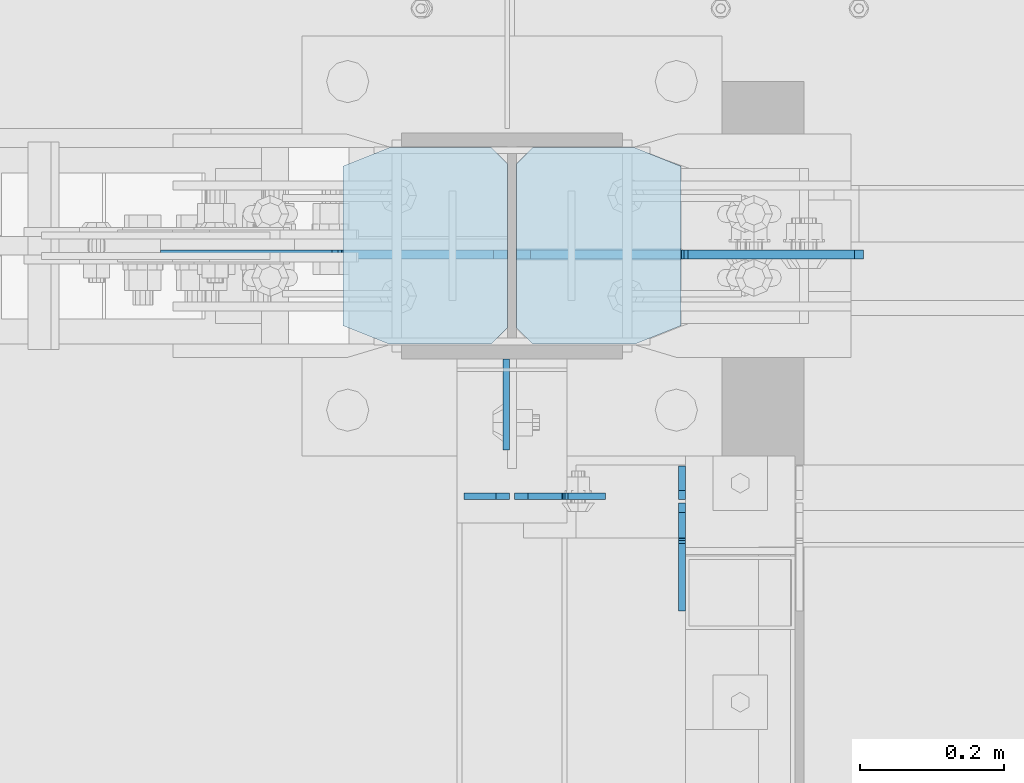
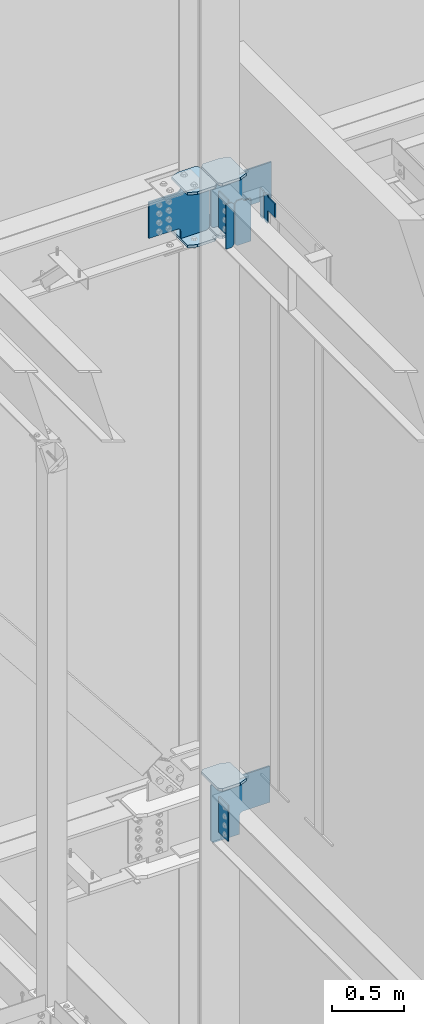
# One storey, part 1106 of 1179: 14 plates, 3 elements without a shape of their own.
"""IFC2X3 building model written with IfcOpenShell, lengths in millimetres."""

from ifc_helpers import new_model, si_unit, frame, origin_with_axes, place, context, subcontext, project, spatial, faceted_brep, material, type_object, element, aggregate, save


model = new_model("IFC2X3")

# Units and contexts
model_context = context("Model", 3, precision=1e-05, world=origin_with_axes())
body_context = subcontext(model_context, "Body", "Model", "MODEL_VIEW")
ifc_project = project(units=[si_unit("LENGTHUNIT", "METRE", prefix="MILLI"), si_unit("AREAUNIT", "SQUARE_METRE"), si_unit("VOLUMEUNIT", "CUBIC_METRE"), si_unit("MASSUNIT", "GRAM", prefix="KILO"), si_unit("TIMEUNIT", "SECOND"), si_unit("PLANEANGLEUNIT", "RADIAN"), si_unit("SOLIDANGLEUNIT", "STERADIAN"), si_unit("THERMODYNAMICTEMPERATUREUNIT", "DEGREE_CELSIUS"), si_unit("LUMINOUSINTENSITYUNIT", "LUMEN")], contexts=[model_context])

# Site, building, storey
site_placement = place(None, origin_with_axes())
site = spatial("IfcSite", under=ifc_project, at=site_placement, CompositionType="ELEMENT")
building_placement = place(site_placement, origin_with_axes())
building = spatial("IfcBuilding", under=site, at=building_placement, Name="Undefined", CompositionType="ELEMENT")
storey_placement = place(building_placement, origin_with_axes())
storey = spatial("IfcBuildingStorey", under=building, at=storey_placement, Name="Undefined", CompositionType="ELEMENT", Elevation=0.0)

# Assembly, plate
assembly_1_placement = place(storey_placement, origin_with_axes())
assembly_1 = element("IfcElementAssembly", 1, at=assembly_1_placement, inside=storey, Name="BEAM", AssemblyPlace="NOTDEFINED", PredefinedType="RIGID_FRAME")
ifc_material_1 = material(Name="STEEL/A36")
plate_type_1 = type_object("IfcPlateType", PredefinedType="NOTDEFINED")
plate_1_placement = place(assembly_1_placement, frame((16462.375, 40850.3442499161, 12728.575), z_axis=(0.0, 0.0, 1.0), x_axis=(1.0, 0.0, 0.0)))
plate_1 = element("IfcPlate", 2, at=plate_1_placement, type_object=plate_type_1, material=ifc_material_1, Name="PLATE", context=body_context, shape_type="Brep", body=[
    faceted_brep([(66.6749998164378, -4.76249999999709, 377.825), (66.6749999434469, -4.76249999999709, 371.474999553748), (66.6749999434469, 4.76249999999709, 371.474999553748), (66.6749998164378, 4.76249999999709, 377.825), (67.641729938794, -4.76249999999709, 366.614920114053), (67.641729938794, 4.76249999999709, 366.614920114053), (70.394743855788, -4.76249999999709, 362.494743732281), (70.394743855788, 4.76249999999709, 362.494743732281), (74.5149202922948, -4.76249999999709, 359.741729897201), (74.5149202922948, 4.76249999999709, 359.741729897201), (79.3749997512095, -4.76249999999709, 358.774999998475), (79.3749997512095, 4.76249999999709, 358.774999998475), (127.000000004868, -4.76249999999709, 358.774999992755), (127.0, 4.76249999999709, 358.774999992755), (0.0, -4.76249999999709, 358.775000762939), (19.0499992370605, -4.76249999999709, 377.825), (19.0499992370605, 4.76249999999709, 377.825), (0.0, 4.76249999999709, 358.775000762939), (0.0, -4.76250000000073, 19.0499992370605), (0.0, 4.76250000000073, 19.0499992370605), (19.0499992370605, -4.76250000000073, 0.0), (19.0499992370605, 4.76250000000073, 0.0), (127.0, -4.76250000000073, 0.0), (127.0, 4.76250000000073, 0.0)], [[[0, 1, 2, 3]], [[4, 5, 2, 1]], [[6, 7, 5, 4]], [[8, 9, 7, 6]], [[10, 11, 9, 8]], [[12, 13, 11, 10]], [[14, 15, 16, 17]], [[18, 14, 17, 19]], [[20, 18, 19, 21]], [[22, 20, 21, 23]], [[8, 6, 4, 1, 0, 15, 14, 18, 20, 22, 12, 10]], [[16, 15, 0, 3]], [[23, 21, 19, 17, 16, 3, 2, 5, 7, 9, 11, 13]], [[22, 23, 13, 12]]]),
])

# Assembly, plates
assembly_2_placement = place(storey_placement, origin_with_axes())
assembly_2 = element("IfcElementAssembly", 3, at=assembly_2_placement, inside=storey, Name="COLUMN", AssemblyPlace="NOTDEFINED", PredefinedType="RIGID_FRAME")
plate_2_placement = place(assembly_2_placement, frame((16451.2625, 41041.6375, 13080.9999983942), z_axis=(0.0, -1.0, 0.0), x_axis=(0.0, 0.0, -1.0)))
plate_2 = element("IfcPlate", 4, at=plate_2_placement, type_object=plate_type_1, material=ifc_material_1, Name="PLATE", context=body_context, shape_type="Brep", body=[
    faceted_brep([(0.0, -4.76249999999709, 0.0), (0.0, -4.76249999999709, 127.0), (0.0, 4.76249999999709, 127.0), (0.0, 4.76249999999709, 0.0), (304.799999999999, -4.76249999999982, 127.0), (304.799999999999, 4.76249999999982, 127.0), (304.799987792969, -4.76250000000073, 0.0), (304.799987792969, 4.76250000000073, 0.0)], [[[0, 1, 2, 3]], [[2, 1, 4, 5]], [[4, 6, 7, 5]], [[6, 0, 3, 7]], [[5, 7, 3, 2]], [[6, 4, 1, 0]]]),
])
plate_3_placement = place(assembly_2_placement, frame((16451.2625, 41041.6375, 7975.59999886453), z_axis=(0.0, -1.0, 0.0), x_axis=(0.0, 0.0, -1.0)))
plate_3 = element("IfcPlate", 5, at=plate_3_placement, type_object=plate_type_1, material=ifc_material_1, Name="PLATE", context=body_context, shape_type="Brep", body=[
    faceted_brep([(0.0, -4.76249999999709, 0.0), (0.0, -4.76249999999709, 127.0), (0.0, 4.76249999999709, 127.0), (0.0, 4.76249999999709, 0.0), (304.799999999999, -4.76249999999982, 127.0), (304.799999999999, 4.76249999999982, 127.0), (304.799987792969, -4.76250000000073, 0.0), (304.799987792969, 4.76250000000073, 0.0)], [[[0, 1, 2, 3]], [[2, 1, 4, 5]], [[4, 6, 7, 5]], [[6, 0, 3, 7]], [[5, 7, 3, 2]], [[6, 4, 1, 0]]]),
])

# Plate
plate_type_2 = type_object("IfcPlateType", PredefinedType="NOTDEFINED")
plate_4_placement = place(assembly_1_placement, frame((16456.025, 40850.3442499161, 12728.575), z_axis=(0.0, 0.0, 1.0), x_axis=(-1.0, 0.0, 0.0)))
plate_4 = element("IfcPlate", 6, at=plate_4_placement, type_object=plate_type_2, material=ifc_material_1, Name="PLATE", context=body_context, shape_type="Brep", body=[
    faceted_brep([(0.0, -4.76250000000073, 19.0499992370605), (0.0, -4.76249999999709, 358.775000762939), (0.0, 4.76249999999709, 358.775000762939), (0.0, 4.76250000000073, 19.0499992370605), (19.0499992370605, -4.76249999999709, 377.825), (19.0499992370605, 4.76249999999709, 377.825), (63.5, -4.76250000000073, 377.825012207031), (63.5, 4.76250000000073, 377.825012207031), (63.5, -4.76250000000073, 0.0), (63.5, 4.76250000000073, 0.0), (19.0499992370605, -4.76250000000073, 0.0), (19.0499992370605, 4.76250000000073, 0.0)], [[[0, 1, 2, 3]], [[1, 4, 5, 2]], [[4, 6, 7, 5]], [[6, 8, 9, 7]], [[8, 10, 11, 9]], [[10, 0, 3, 11]], [[5, 7, 9, 11, 3, 2]], [[10, 8, 6, 4, 1, 0]]]),
])

aggregate(assembly_1, [plate_4, plate_1])

# Assembly, plate
assembly_3_placement = place(storey_placement, origin_with_axes())
assembly_3 = element("IfcElementAssembly", 7, at=assembly_3_placement, inside=storey, Name="BEAM", AssemblyPlace="NOTDEFINED", PredefinedType="RIGID_FRAME")
plate_type_3 = type_object("IfcPlateType", PredefinedType="NOTDEFINED")
plate_5_placement = place(assembly_3_placement, frame((16695.7374982185, 40845.58125, 12874.625), z_axis=(0.0, 0.0, 1.0), x_axis=(0.0, 1.0, 0.0)))
plate_5 = element("IfcPlate", 8, at=plate_5_placement, type_object=plate_type_3, material=ifc_material_1, Name="PLATE", context=body_context, shape_type="Brep", body=[
    faceted_brep([(-2.72848410531878e-12, -4.76249999998981, 12.6999998092615), (0.0, -4.76250000000073, 225.425000190735), (0.0, 4.76250000000073, 225.425000190735), (-2.72848410531878e-12, 4.76250000000437, 12.699999809256), (12.6999998092651, -4.76250000000073, 238.125), (12.6999998092651, 4.76250000000073, 238.125), (46.8312500000029, -4.76250000000073, 238.125), (46.8312500000029, 4.76250000000073, 238.125), (46.8312500000029, -4.76249999999982, 0.0), (46.8312500000029, 4.76249999999982, 0.0), (12.6999998092651, -4.76249999999527, 1.81898940354586e-12), (12.6999998092651, 4.76250000000073, 0.0)], [[[0, 1, 2, 3]], [[1, 4, 5, 2]], [[4, 6, 7, 5]], [[6, 8, 9, 7]], [[8, 10, 11, 9]], [[10, 0, 3, 11]], [[5, 7, 9, 11, 3, 2]], [[10, 8, 6, 4, 1, 0]]]),
])

# Plate
ifc_material_2 = material(Name="STEEL/A572-GR.50")
plate_type_4 = type_object("IfcPlateType", PredefinedType="NOTDEFINED")
plate_6_placement = place(assembly_2_placement, frame((16224.25, 41335.325, 12663.4875), z_axis=(0.0, -1.0, 0.0), x_axis=(1.0, 0.0, 0.0)))
plate_6 = element("IfcPlate", 9, at=plate_6_placement, type_object=plate_type_4, material=ifc_material_2, Name="PLATE", context=body_context, shape_type="Brep", body=[
    faceted_brep([(0.0, -11.1125000000002, 25.3999996185303), (0.0, -11.1125000000002, 247.650000381473), (0.0, 11.1125000000002, 247.650000381473), (0.0, 11.1125000000002, 25.3999996185303), (63.5, -11.1125000000002, 273.050000000003), (63.5, 11.1125000000002, 273.050000000003), (206.374999618529, -11.1125000000002, 273.050000000003), (206.374999618529, 11.1125000000002, 273.050000000003), (228.599999999999, -11.1125000000002, 250.824999618533), (228.599999999999, 11.1125000000002, 250.824999618533), (228.599999999999, -11.1125000000002, 22.2250003814697), (228.599999999999, 11.1125000000002, 22.2250003814697), (206.374999618529, -11.1125000000002, 0.0), (206.374999618529, 11.1125000000002, 0.0), (63.5, -11.1125000000002, 0.0), (63.5, 11.1125000000002, 0.0)], [[[0, 1, 2, 3]], [[1, 4, 5, 2]], [[4, 6, 7, 5]], [[6, 8, 9, 7]], [[8, 10, 11, 9]], [[10, 12, 13, 11]], [[12, 14, 15, 13]], [[14, 0, 3, 15]], [[5, 7, 9, 11, 13, 15, 3, 2]], [[14, 12, 10, 8, 6, 4, 1, 0]]]),
])

plate_7_placement = place(assembly_2_placement, frame((16224.25, 41335.325, 13107.9875), z_axis=(0.0, -1.0, 0.0), x_axis=(1.0, 0.0, 0.0)))
plate_7 = element("IfcPlate", 10, at=plate_7_placement, type_object=plate_type_4, material=ifc_material_2, Name="PLATE", context=body_context, shape_type="Brep", body=[
    faceted_brep([(0.0, -11.1125000000002, 25.3999996185303), (0.0, -11.1125000000002, 247.650000381473), (0.0, 11.1125000000002, 247.650000381473), (0.0, 11.1125000000002, 25.3999996185303), (63.5, -11.1125000000002, 273.050000000003), (63.5, 11.1125000000002, 273.050000000003), (206.374999618529, -11.1125000000002, 273.050000000003), (206.374999618529, 11.1125000000002, 273.050000000003), (228.599999999999, -11.1125000000002, 250.824999618533), (228.599999999999, 11.1125000000002, 250.824999618533), (228.599999999999, -11.1125000000002, 22.2250003814697), (228.599999999999, 11.1125000000002, 22.2250003814697), (206.374999618529, -11.1125000000002, 0.0), (206.374999618529, 11.1125000000002, 0.0), (63.5, -11.1125000000002, 0.0), (63.5, 11.1125000000002, 0.0)], [[[0, 1, 2, 3]], [[1, 4, 5, 2]], [[4, 6, 7, 5]], [[6, 8, 9, 7]], [[8, 10, 11, 9]], [[10, 12, 13, 11]], [[12, 14, 15, 13]], [[14, 0, 3, 15]], [[5, 7, 9, 11, 13, 15, 3, 2]], [[14, 12, 10, 8, 6, 4, 1, 0]]]),
])

plate_8_placement = place(assembly_2_placement, frame((16694.15, 41062.275, 12663.4875), z_axis=(0.0, 1.0, 0.0), x_axis=(-1.0, 0.0, 0.0)))
plate_8 = element("IfcPlate", 11, at=plate_8_placement, type_object=plate_type_4, material=ifc_material_2, Name="PLATE", context=body_context, shape_type="Brep", body=[
    faceted_brep([(0.0, -11.1125000000002, 25.3999996185303), (0.0, -11.1125000000002, 247.650000381473), (0.0, 11.1125000000002, 247.650000381473), (0.0, 11.1125000000002, 25.3999996185303), (63.5, -11.1125000000002, 273.050000000003), (63.5, 11.1125000000002, 273.050000000003), (206.374999618529, -11.1125000000002, 273.050000000003), (206.374999618529, 11.1125000000002, 273.050000000003), (228.599999999999, -11.1125000000002, 250.824999618533), (228.599999999999, 11.1125000000002, 250.824999618533), (228.599999999999, -11.1125000000002, 22.2250003814697), (228.599999999999, 11.1125000000002, 22.2250003814697), (206.374999618529, -11.1125000000002, 0.0), (206.374999618529, 11.1125000000002, 0.0), (63.5, -11.1125000000002, 0.0), (63.5, 11.1125000000002, 0.0)], [[[0, 1, 2, 3]], [[1, 4, 5, 2]], [[4, 6, 7, 5]], [[6, 8, 9, 7]], [[8, 10, 11, 9]], [[10, 12, 13, 11]], [[12, 14, 15, 13]], [[14, 0, 3, 15]], [[5, 7, 9, 11, 13, 15, 3, 2]], [[14, 12, 10, 8, 6, 4, 1, 0]]]),
])

plate_9_placement = place(assembly_2_placement, frame((16694.15, 41062.275, 13107.9875), z_axis=(0.0, 1.0, 0.0), x_axis=(-1.0, 0.0, 0.0)))
plate_9 = element("IfcPlate", 12, at=plate_9_placement, type_object=plate_type_4, material=ifc_material_2, Name="PLATE", context=body_context, shape_type="Brep", body=[
    faceted_brep([(0.0, -11.1125000000002, 25.3999996185303), (0.0, -11.1125000000002, 247.650000381473), (0.0, 11.1125000000002, 247.650000381473), (0.0, 11.1125000000002, 25.3999996185303), (63.5, -11.1125000000002, 273.050000000003), (63.5, 11.1125000000002, 273.050000000003), (206.374999618529, -11.1125000000002, 273.050000000003), (206.374999618529, 11.1125000000002, 273.050000000003), (228.599999999999, -11.1125000000002, 250.824999618533), (228.599999999999, 11.1125000000002, 250.824999618533), (228.599999999999, -11.1125000000002, 22.2250003814697), (228.599999999999, 11.1125000000002, 22.2250003814697), (206.374999618529, -11.1125000000002, 0.0), (206.374999618529, 11.1125000000002, 0.0), (63.5, -11.1125000000002, 0.0), (63.5, 11.1125000000002, 0.0)], [[[0, 1, 2, 3]], [[1, 4, 5, 2]], [[4, 6, 7, 5]], [[6, 8, 9, 7]], [[8, 10, 11, 9]], [[10, 12, 13, 11]], [[12, 14, 15, 13]], [[14, 0, 3, 15]], [[5, 7, 9, 11, 13, 15, 3, 2]], [[14, 12, 10, 8, 6, 4, 1, 0]]]),
])

plate_10_placement = place(assembly_2_placement, frame((16694.15, 41062.275, 8002.5875), z_axis=(0.0, 1.0, 0.0), x_axis=(-1.0, 0.0, 0.0)))
plate_10 = element("IfcPlate", 13, at=plate_10_placement, type_object=plate_type_4, material=ifc_material_2, Name="PLATE", context=body_context, shape_type="Brep", body=[
    faceted_brep([(0.0, -11.1125000000002, 25.3999996185303), (0.0, -11.1125000000002, 247.650000381473), (0.0, 11.1125000000002, 247.650000381473), (0.0, 11.1125000000002, 25.3999996185303), (63.5, -11.1125000000002, 273.050000000003), (63.5, 11.1125000000002, 273.050000000003), (206.374999618529, -11.1125000000002, 273.050000000003), (206.374999618529, 11.1125000000002, 273.050000000003), (228.599999999999, -11.1125000000002, 250.824999618533), (228.599999999999, 11.1125000000002, 250.824999618533), (228.599999999999, -11.1125000000002, 22.2250003814697), (228.599999999999, 11.1125000000002, 22.2250003814697), (206.374999618529, -11.1125000000002, 0.0), (206.374999618529, 11.1125000000002, 0.0), (63.5, -11.1125000000002, 0.0), (63.5, 11.1125000000002, 0.0)], [[[0, 1, 2, 3]], [[1, 4, 5, 2]], [[4, 6, 7, 5]], [[6, 8, 9, 7]], [[8, 10, 11, 9]], [[10, 12, 13, 11]], [[12, 14, 15, 13]], [[14, 0, 3, 15]], [[5, 7, 9, 11, 13, 15, 3, 2]], [[14, 12, 10, 8, 6, 4, 1, 0]]]),
])

plate_type_5 = type_object("IfcPlateType", PredefinedType="NOTDEFINED")
plate_11_placement = place(assembly_2_placement, frame((16452.8499999723, 41186.89375, 12693.65), z_axis=(-0.707106781186532, 0.0, 0.707106781186563), x_axis=(-0.707106781186564, 0.0, -0.707106781186531)))
plate_11 = element("IfcPlate", 14, at=plate_11_placement, type_object=plate_type_5, material=ifc_material_2, Name="PLATE", context=body_context, shape_type="Brep", body=[
    faceted_brep([(0.0, -6.34999999999854, 0.0), (-271.652749686205, -6.35000000000036, 271.652745638487), (-271.652749686205, 6.35000000000036, 271.652745638487), (0.0, 6.34999999999854, 0.0), (-271.652749686187, -6.35000000000036, 298.59351380097), (-271.652749686187, 6.35000000000036, 298.59351380097), (-123.478521665553, -6.34999999999854, 446.767742022512), (-123.478521665553, 6.34999999999854, 446.767742022512), (-121.233457365147, -6.34999999999854, 444.522677722911), (-121.233457365147, 6.34999999999854, 444.522677722911), (-112.993104428839, -6.34999999999854, 439.016649921954), (-112.993104428839, 6.34999999999854, 439.016649921954), (-103.272945392747, -6.34999999999854, 437.083190076777), (-103.272945392747, 6.34999999999854, 437.083190076777), (-93.5527863566531, -6.34999999999854, 439.016649921954), (-93.5527863566531, 6.34999999999854, 439.016649921954), (-85.3124334203458, -6.34999999999854, 444.522677722913), (-85.3124334203458, 6.34999999999854, 444.522677722913), (76.3321770282328, -6.34999999999854, 606.167288171488), (76.3321770282328, 6.34999999999854, 606.167288171488), (291.858323933965, -6.34999999999854, 390.641141265758), (291.858323933965, 6.34999999999854, 390.641141265758), (130.213713485389, -6.34999999999854, 228.996530817178), (130.213713485389, 6.34999999999854, 228.996530817178), (124.707685684432, -6.34999999999854, 220.756177880869), (124.707685684432, 6.34999999999854, 220.756177880869), (122.774225839255, -6.34999999999854, 211.036018844778), (122.774225839255, 6.34999999999854, 211.036018844778), (124.707685684432, -6.34999999999854, 201.315859808683), (124.707685684432, 6.34999999999854, 201.315859808683), (130.21371348539, -6.34999999999854, 193.075506872374), (130.21371348539, 6.34999999999854, 193.075506872374), (175.114994360907, -6.34999999999854, 148.174225997692), (175.114994360907, 6.34999999999854, 148.174225997692), (26.9407683631471, -6.34999999999854, -6.91215973347425e-11), (26.9407683631471, 6.34999999999854, -6.91215973347425e-11)], [[[0, 1, 2, 3]], [[1, 4, 5, 2]], [[4, 6, 7, 5]], [[6, 8, 9, 7]], [[8, 10, 11, 9]], [[10, 12, 13, 11]], [[12, 14, 15, 13]], [[14, 16, 17, 15]], [[16, 18, 19, 17]], [[18, 20, 21, 19]], [[20, 22, 23, 21]], [[22, 24, 25, 23]], [[24, 26, 27, 25]], [[26, 28, 29, 27]], [[28, 30, 31, 29]], [[30, 32, 33, 31]], [[32, 34, 35, 33]], [[34, 0, 3, 35]], [[5, 7, 9, 11, 13, 15, 17, 19, 21, 23, 25, 27, 29, 31, 33, 35, 3, 2]], [[34, 32, 30, 28, 26, 24, 22, 20, 18, 16, 14, 12, 10, 8, 6, 4, 1, 0]]]),
])

plate_12_placement = place(assembly_2_placement, frame((16465.55, 41186.89375, 12693.65), z_axis=(0.707106781186573, 0.0, 0.707106781186522), x_axis=(0.707106781186522, 0.0, -0.707106781186573)))
plate_12 = element("IfcPlate", 15, at=plate_12_placement, type_object=plate_type_5, material=ifc_material_2, Name="PLATE", context=body_context, shape_type="Brep", body=[
    faceted_brep([(0.0, -6.34999999999854, 0.0), (-271.652749686205, -6.35000000000036, 271.652745638487), (-271.652749686205, 6.35000000000036, 271.652745638487), (0.0, 6.34999999999854, 0.0), (-271.652749686187, -6.35000000000036, 298.59351380097), (-271.652749686187, 6.35000000000036, 298.59351380097), (-123.478521665553, -6.34999999999854, 446.767742022512), (-123.478521665553, 6.34999999999854, 446.767742022512), (-121.233457365147, -6.34999999999854, 444.522677722911), (-121.233457365147, 6.34999999999854, 444.522677722911), (-112.993104428839, -6.34999999999854, 439.016649921954), (-112.993104428839, 6.34999999999854, 439.016649921954), (-103.272945392747, -6.34999999999854, 437.083190076777), (-103.272945392747, 6.34999999999854, 437.083190076777), (-93.5527863566531, -6.34999999999854, 439.016649921954), (-93.5527863566531, 6.34999999999854, 439.016649921954), (-85.3124334203458, -6.34999999999854, 444.522677722913), (-85.3124334203458, 6.34999999999854, 444.522677722913), (76.3321770282328, -6.34999999999854, 606.167288171488), (76.3321770282328, 6.34999999999854, 606.167288171488), (291.858323933965, -6.34999999999854, 390.641141265758), (291.858323933965, 6.34999999999854, 390.641141265758), (130.213713485389, -6.34999999999854, 228.996530817178), (130.213713485389, 6.34999999999854, 228.996530817178), (124.707685684432, -6.34999999999854, 220.756177880869), (124.707685684432, 6.34999999999854, 220.756177880869), (122.774225839255, -6.34999999999854, 211.036018844778), (122.774225839255, 6.34999999999854, 211.036018844778), (124.707685684432, -6.34999999999854, 201.315859808683), (124.707685684432, 6.34999999999854, 201.315859808683), (130.21371348539, -6.34999999999854, 193.075506872374), (130.21371348539, 6.34999999999854, 193.075506872374), (175.114994360907, -6.34999999999854, 148.174225997692), (175.114994360907, 6.34999999999854, 148.174225997692), (26.9407683631471, -6.34999999999854, -6.91215973347425e-11), (26.9407683631471, 6.34999999999854, -6.91215973347425e-11)], [[[0, 1, 2, 3]], [[1, 4, 5, 2]], [[4, 6, 7, 5]], [[6, 8, 9, 7]], [[8, 10, 11, 9]], [[10, 12, 13, 11]], [[12, 14, 15, 13]], [[14, 16, 17, 15]], [[16, 18, 19, 17]], [[18, 20, 21, 19]], [[20, 22, 23, 21]], [[22, 24, 25, 23]], [[24, 26, 27, 25]], [[26, 28, 29, 27]], [[28, 30, 31, 29]], [[30, 32, 33, 31]], [[32, 34, 35, 33]], [[34, 0, 3, 35]], [[5, 7, 9, 11, 13, 15, 17, 19, 21, 23, 25, 27, 29, 31, 33, 35, 3, 2]], [[34, 32, 30, 28, 26, 24, 22, 20, 18, 16, 14, 12, 10, 8, 6, 4, 1, 0]]]),
])

plate_type_6 = type_object("IfcPlateType", PredefinedType="NOTDEFINED")
plate_13_placement = place(assembly_2_placement, frame((16465.5500001352, 41186.89375, 7505.70000161612), z_axis=(0.707106781186573, 0.0, 0.707106781186522), x_axis=(0.707106781186522, 0.0, -0.707106781186573)))
plate_13 = element("IfcPlate", 16, at=plate_13_placement, type_object=plate_type_6, material=ifc_material_2, Name="PLATE", context=body_context, shape_type="Brep", body=[
    faceted_brep([(0.0, -6.34999999999854, 0.0), (-330.024413368445, -6.34999999999854, 330.024412354549), (-330.024413368445, 6.34999999999854, 330.024412354549), (0.0, 6.34999999999854, 0.0), (-330.024413368415, -6.34999999999854, 356.965180717838), (-330.024413368415, 6.34999999999854, 356.965180717838), (-181.850187371498, -6.34999999999854, 505.139406716142), (-181.850187371498, 6.34999999999854, 505.139406716142), (-176.699966708946, -6.34999999999854, 501.69813928883), (-176.699966708946, 6.34999999999854, 501.69813928883), (-170.624867220123, -6.34999999999854, 500.489726867436), (-170.624867220123, 6.34999999999854, 500.489726867436), (-164.549767731302, -6.34999999999854, 501.698139288826), (-164.549767731302, 6.34999999999854, 501.698139288826), (-159.399547068744, -6.34999999999854, 505.139406716142), (-159.399547068744, 6.34999999999854, 505.139406716142), (-9.20527782000136e-07, -6.34999999999854, 664.538952865623), (-9.20527782000136e-07, 6.34999999999854, 664.538952865623), (215.526145983725, -6.34999999999854, 449.012805959483), (215.526145983725, 6.34999999999854, 449.012805959483), (62.8617917264401, -6.34999999999854, 296.348451700989), (62.8617917264401, 6.34999999999854, 296.348451700989), (57.3557639160445, -6.34999999999854, 288.108098741799), (57.3557639160445, 6.34999999999854, 288.108098741799), (55.4223040803718, -6.34999999999854, 278.387939679073), (55.4223040803718, 6.34999999999854, 278.387939679073), (57.3557639539831, -6.34999999999854, 268.667780623895), (57.3557639539831, 6.34999999999854, 268.667780623895), (62.861791796543, -6.34999999999854, 260.427427686202), (62.861791796543, 6.34999999999854, 260.427427686202), (175.114994360907, -6.34999999999854, 148.174225997692), (175.114994360907, 6.34999999999854, 148.174225997692), (26.9407683631471, -6.34999999999854, -6.91215973347425e-11), (26.9407683631471, 6.34999999999854, -6.91215973347425e-11)], [[[0, 1, 2, 3]], [[1, 4, 5, 2]], [[4, 6, 7, 5]], [[6, 8, 9, 7]], [[8, 10, 11, 9]], [[10, 12, 13, 11]], [[12, 14, 15, 13]], [[14, 16, 17, 15]], [[16, 18, 19, 17]], [[18, 20, 21, 19]], [[20, 22, 23, 21]], [[22, 24, 25, 23]], [[24, 26, 27, 25]], [[26, 28, 29, 27]], [[28, 30, 31, 29]], [[30, 32, 33, 31]], [[32, 0, 3, 33]], [[5, 7, 9, 11, 13, 15, 17, 19, 21, 23, 25, 27, 29, 31, 33, 3, 2]], [[32, 30, 28, 26, 24, 22, 20, 18, 16, 14, 12, 10, 8, 6, 4, 1, 0]]]),
])

aggregate(assembly_2, [plate_6, plate_7, plate_11, plate_2, plate_8, plate_9, plate_12, plate_3, plate_10, plate_13])

plate_type_7 = type_object("IfcPlateType", PredefinedType="NOTDEFINED")
plate_14_placement = place(assembly_3_placement, frame((16695.7374968283, 40840.81875, 13112.75), z_axis=(0.0, -1.0, 0.0), x_axis=(0.0, 0.0, -1.0)))
plate_14 = element("IfcPlate", 17, at=plate_14_placement, type_object=plate_type_7, material=ifc_material_1, Name="PLATE", context=body_context, shape_type="Brep", body=[
    faceted_brep([(4.8600797445506, -4.76249999992433, 49.3854800566332), (4.8600797445506, 4.76250000007713, 49.3854798566099), (-1.45519152283669e-11, 4.76249999999345, 48.4187388288169), (-9.09494701772928e-12, -4.76249999999891, 48.4187388288169), (8.98025619343389, -4.76249999991705, 52.138493985949), (8.98025619343389, 4.76250000008076, 52.1384937859257), (11.7332700650695, -4.76249999990978, 56.2586704733694), (11.7332700650695, 4.76250000009168, 56.2586702733461), (12.6999999536365, -4.7624999999025, 61.1187499981825), (12.6999999536365, 4.76250000009532, 61.1187497981591), (12.6999993313366, -4.76249999976426, 150.018738193074), (12.6999993313366, 4.7625000002372, 150.018738193059), (12.6999998092651, -4.76249999999527, 1.81898940354586e-12), (-2.72848410531878e-12, -4.76249999998981, 12.6999998092615), (-2.72848410531878e-12, 4.76250000000437, 12.699999809256), (12.6999998092651, 4.76250000000073, 0.0), (225.425000190735, -4.76250000000073, -6.54836185276508e-11), (225.425000190735, 4.76250000000073, -8.00355337560177e-11), (238.124999073794, -4.7624999999789, 12.6999998091924), (238.124999073794, 4.76250000001892, 12.6999998091778), (238.124996468841, -4.76249999992433, 48.418751110039), (238.124996468841, 4.76250000007713, 48.4187511100245), (139.700008964539, -4.76250000007713, 48.4187507629322), (139.700008964539, 4.76249999992433, 48.4187507629395), (134.839929446493, -4.76250000007713, 49.3854806855161), (134.839929446493, 4.76249999992433, 49.3854806855306), (130.719752978339, -4.76250000008076, 52.1384945859973), (130.719752978339, 4.76249999991705, 52.1384945860118), (127.966739077861, -4.76250000008804, 56.2586710541509), (127.966739077861, 4.76249999991342, 56.2586710541655), (127.000009155274, -4.76250000009532, 61.1187505721973), (127.000009155274, 4.7624999999025, 61.1187505722046), (127.000009155274, -4.7625000002372, 150.018753051751), (127.000009155274, 4.76249999976426, 150.018753051758)], [[[0, 1, 2, 3]], [[4, 5, 1, 0]], [[6, 7, 5, 4]], [[8, 9, 7, 6]], [[10, 11, 9, 8]], [[12, 13, 14, 15]], [[16, 12, 15, 17]], [[18, 16, 17, 19]], [[20, 18, 19, 21]], [[22, 20, 21, 23]], [[24, 22, 23, 25]], [[26, 24, 25, 27]], [[28, 26, 27, 29]], [[30, 28, 29, 31]], [[32, 30, 31, 33]], [[6, 4, 0, 3, 13, 12, 16, 18, 20, 22, 24, 26, 28, 30, 32, 10, 8]], [[14, 13, 3, 2]], [[33, 31, 29, 27, 25, 23, 21, 19, 17, 15, 14, 2, 1, 5, 7, 9, 11]], [[32, 33, 11, 10]]]),
])

aggregate(assembly_3, [plate_5, plate_14])

save(model, "model.ifc")
